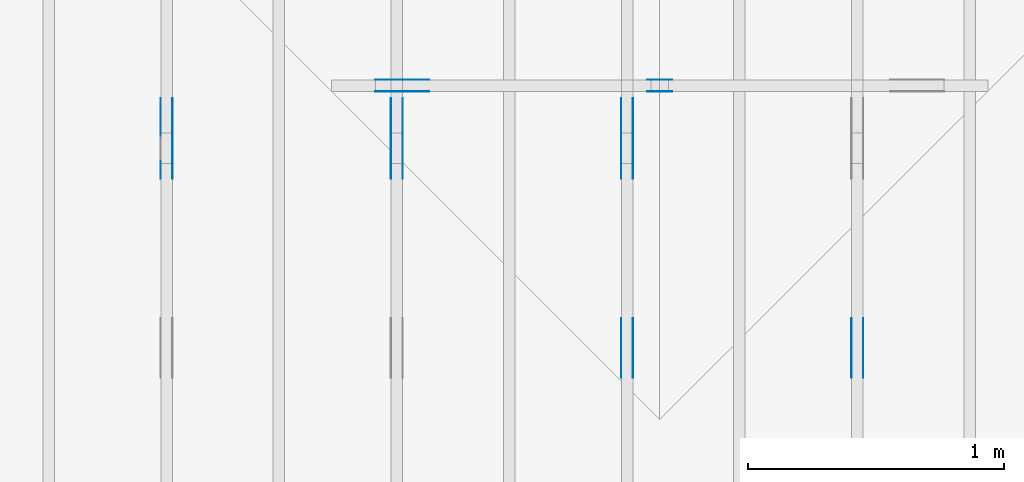
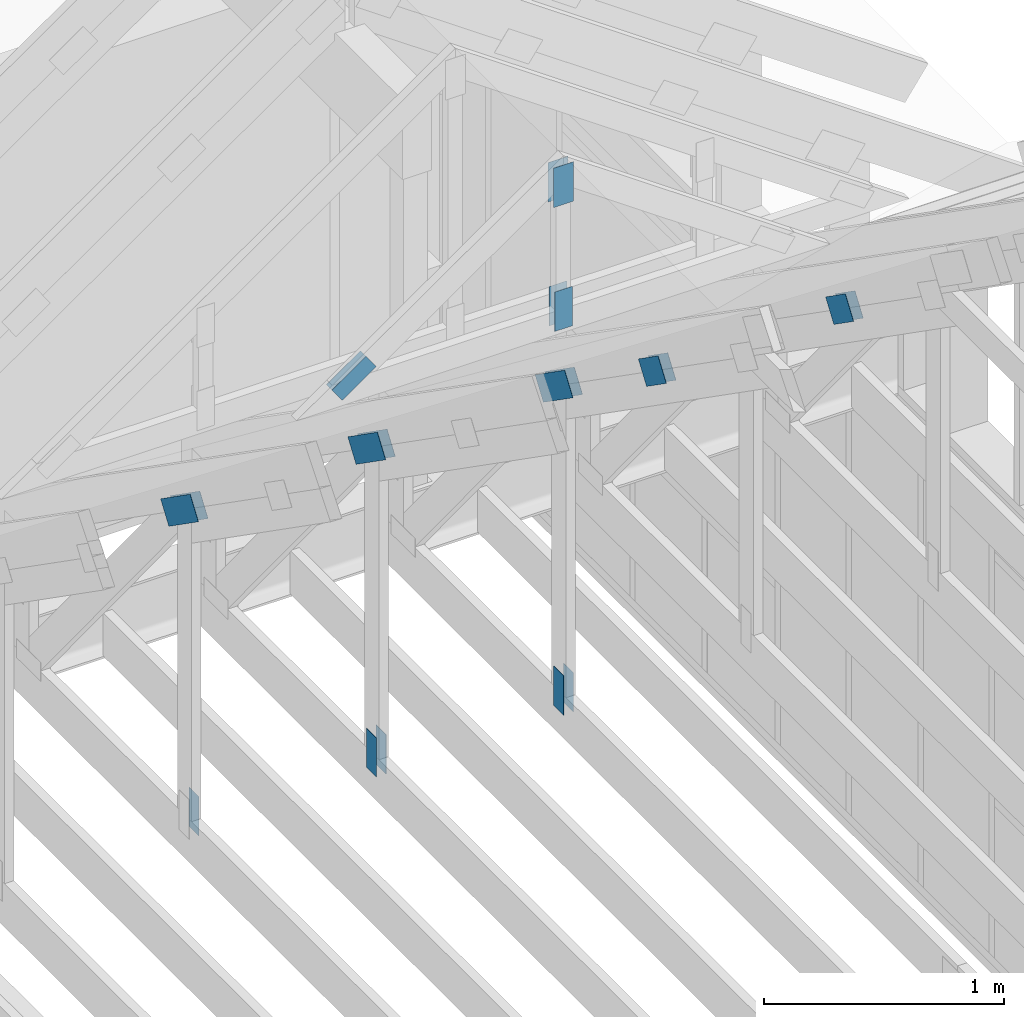
# One storey, part 57 of 70: 21 plates, 5 elements without a shape of their own.
"""IFC2X3 building model written with IfcOpenShell, lengths in millimetres."""

from ifc_helpers import new_model, si_unit, frame, origin, origin_with_axes, origin_2d, place, context, project, spatial, faceted_brep, element, aggregate, save


model = new_model("IFC2X3")

# Units and contexts
model_context = context("Model", 3, precision=1e-05, world=origin())
plan_context = context("Plan", 2, precision=1e-05, world=origin_2d())
ifc_project = project(units=[si_unit("LENGTHUNIT", "METRE", prefix="MILLI"), si_unit("AREAUNIT", "SQUARE_METRE"), si_unit("VOLUMEUNIT", "CUBIC_METRE"), si_unit("SOLIDANGLEUNIT", "STERADIAN"), si_unit("PLANEANGLEUNIT", "RADIAN"), si_unit("MASSUNIT", "GRAM"), si_unit("TIMEUNIT", "SECOND"), si_unit("THERMODYNAMICTEMPERATUREUNIT", "DEGREE_CELSIUS"), si_unit("LUMINOUSINTENSITYUNIT", "LUMEN")], contexts=[model_context, plan_context])

# Site, building, storey
site_placement = place(None, origin_with_axes())
site = spatial("IfcSite", under=ifc_project, at=site_placement, CompositionType="ELEMENT")
building_placement = place(site_placement, origin_with_axes())
building = spatial("IfcBuilding", under=site, at=building_placement, Name="Layout 1", CompositionType="ELEMENT")
storey_placement = place(building_placement, origin_with_axes())
storey = spatial("IfcBuildingStorey", under=building, at=storey_placement, Name="Storey 1", CompositionType="ELEMENT", Elevation=0.0)

# Assembly, plates
assembly_1_placement = place(storey_placement, frame((10250.0, 8000.0, -9.081170196248781e-13), z_axis=(-1.0, 1.836909530733566e-16, 6.123031769111886e-17), x_axis=(-1.836909530733566e-16, -1.0, 0.0)))
assembly_1 = element("IfcElementAssembly", 1, at=assembly_1_placement, inside=storey, Name="T3", AssemblyPlace="FACTORY", PredefinedType="TRUSS")
plate_1_placement = place(assembly_1_placement, frame((2172.1001375452647, 2209.623369923266, 0.0), z_axis=(0.0, 0.0, 1.0), x_axis=(0.8191520442889915, 0.5735764363510465, 0.0)))
plate_1 = element("IfcPlate", 2, at=plate_1_placement, context=model_context, shape_type="Brep", body=[
    faceted_brep([(200.00000000000045, 120.0, 1.3), (0.0, 120.0, 1.3), (0.0, 0.0, 1.3), (200.00000000000045, 0.0, 1.3), (0.0, 120.0, 0.0), (200.00000000000045, 120.0, 2.4492127076447602e-14), (200.00000000000045, 2.2737367544323206e-13, 2.4492127076447602e-14), (0.0, 2.2737367544323206e-13, 0.0), (200.00000000000045, 1.4089749332535406e-13, 5.2949641037927226e-30), (200.00000000000045, 1.4097709273835252e-13, 1.3), (-5.607678880825911e-32, 7.959941299845453e-17, 1.3), (0.0, 0.0, 0.0), (200.00000000000045, 120.00000000000023, 0.0), (200.00000000000045, 120.00000000000023, 1.3), (200.00000000000045, 2.2737367544323206e-13, 1.3), (200.00000000000045, 2.2737367544323206e-13, 0.0), (0.0, 120.0, 0.0), (0.0, 120.0, 1.3), (200.00000000000043, 120.00000000000021, 1.3), (200.00000000000043, 120.00000000000021, -1.5777218104420236e-30), (0.0, 0.0, 0.0), (7.959941299845453e-17, -9.747794691843893e-33, 1.3), (1.477487565886698e-14, 120.0, 1.3), (1.4695276245868527e-14, 120.0, -8.997964330932825e-31)], [[[0, 1, 2, 3]], [[4, 5, 6, 7]], [[8, 9, 10, 11]], [[12, 13, 14, 15]], [[16, 17, 18, 19]], [[20, 21, 22, 23]]]),
])
plate_2_placement = place(assembly_1_placement, frame((2172.1001375452647, 2209.623369923266, -46.29999999999999), z_axis=(0.0, 0.0, 1.0), x_axis=(0.8191520442889915, 0.5735764363510465, 0.0)))
plate_2 = element("IfcPlate", 3, at=plate_2_placement, context=model_context, shape_type="Brep", body=[
    faceted_brep([(200.00000000000045, 120.0, 1.2999999999999972), (0.0, 120.0, 1.2999999999999972), (0.0, 0.0, 1.2999999999999972), (200.00000000000045, 0.0, 1.2999999999999972), (0.0, 120.0, 0.0), (200.00000000000045, 120.0, 2.4492127076447602e-14), (200.00000000000045, 2.2737367544323206e-13, 2.4492127076447602e-14), (0.0, 2.2737367544323206e-13, 0.0), (200.00000000000045, 1.4089749332535406e-13, 5.2949641037927226e-30), (200.00000000000045, 1.4097709273835252e-13, 1.2999999999999972), (-5.607678880825899e-32, 7.959941299845434e-17, 1.2999999999999972), (0.0, 0.0, 0.0), (200.00000000000045, 120.00000000000023, 0.0), (200.00000000000045, 120.00000000000023, 1.2999999999999972), (200.00000000000045, 2.2737367544323206e-13, 1.2999999999999972), (200.00000000000045, 2.2737367544323206e-13, 0.0), (0.0, 120.0, 0.0), (0.0, 120.0, 1.2999999999999972), (200.00000000000043, 120.00000000000021, 1.2999999999999972), (200.00000000000043, 120.00000000000021, -1.5777218104420236e-30), (0.0, 0.0, 0.0), (7.959941299845434e-17, -9.747794691843873e-33, 1.2999999999999972), (1.477487565886698e-14, 120.0, 1.2999999999999972), (1.4695276245868527e-14, 120.0, -8.997964330932825e-31)], [[[0, 1, 2, 3]], [[4, 5, 6, 7]], [[8, 9, 10, 11]], [[12, 13, 14, 15]], [[16, 17, 18, 19]], [[20, 21, 22, 23]]]),
])
aggregate(assembly_1, [plate_1, plate_2])

assembly_2_placement = place(storey_placement, frame((9350.0, 8000.0, -9.081170196248781e-13), z_axis=(-1.0, 1.836909530733566e-16, 6.123031769111886e-17), x_axis=(-1.836909530733566e-16, -1.0, 0.0)))
assembly_2 = element("IfcElementAssembly", 4, at=assembly_2_placement, inside=storey, Name="T3", AssemblyPlace="FACTORY", PredefinedType="TRUSS")
plate_3_placement = place(assembly_2_placement, frame((2172.1001375452647, 2209.623369923266, 0.0), z_axis=(0.0, 0.0, 1.0), x_axis=(0.8191520442889915, 0.5735764363510465, 0.0)))
plate_3 = element("IfcPlate", 5, at=plate_3_placement, context=model_context, shape_type="Brep", body=[
    faceted_brep([(200.00000000000045, 120.0, 1.3), (0.0, 120.0, 1.3), (0.0, 0.0, 1.3), (200.00000000000045, 0.0, 1.3), (0.0, 120.0, 0.0), (200.00000000000045, 120.0, 2.4492127076447602e-14), (200.00000000000045, 2.2737367544323206e-13, 2.4492127076447602e-14), (0.0, 2.2737367544323206e-13, 0.0), (200.00000000000045, 1.4089749332535406e-13, 5.2949641037927226e-30), (200.00000000000045, 1.4097709273835252e-13, 1.3), (-5.607678880825911e-32, 7.959941299845453e-17, 1.3), (0.0, 0.0, 0.0), (200.00000000000045, 120.00000000000023, 0.0), (200.00000000000045, 120.00000000000023, 1.3), (200.00000000000045, 2.2737367544323206e-13, 1.3), (200.00000000000045, 2.2737367544323206e-13, 0.0), (0.0, 120.0, 0.0), (0.0, 120.0, 1.3), (200.00000000000043, 120.00000000000021, 1.3), (200.00000000000043, 120.00000000000021, -1.5777218104420236e-30), (0.0, 0.0, 0.0), (7.959941299845453e-17, -9.747794691843893e-33, 1.3), (1.477487565886698e-14, 120.0, 1.3), (1.4695276245868527e-14, 120.0, -8.997964330932825e-31)], [[[0, 1, 2, 3]], [[4, 5, 6, 7]], [[8, 9, 10, 11]], [[12, 13, 14, 15]], [[16, 17, 18, 19]], [[20, 21, 22, 23]]]),
])
plate_4_placement = place(assembly_2_placement, frame((2172.1001375452647, 2209.623369923266, -46.29999999999999), z_axis=(0.0, 0.0, 1.0), x_axis=(0.8191520442889915, 0.5735764363510465, 0.0)))
plate_4 = element("IfcPlate", 6, at=plate_4_placement, context=model_context, shape_type="Brep", body=[
    faceted_brep([(200.00000000000045, 120.0, 1.2999999999999972), (0.0, 120.0, 1.2999999999999972), (0.0, 0.0, 1.2999999999999972), (200.00000000000045, 0.0, 1.2999999999999972), (0.0, 120.0, 0.0), (200.00000000000045, 120.0, 2.4492127076447602e-14), (200.00000000000045, 2.2737367544323206e-13, 2.4492127076447602e-14), (0.0, 2.2737367544323206e-13, 0.0), (200.00000000000045, 1.4089749332535406e-13, 5.2949641037927226e-30), (200.00000000000045, 1.4097709273835252e-13, 1.2999999999999972), (-5.607678880825899e-32, 7.959941299845434e-17, 1.2999999999999972), (0.0, 0.0, 0.0), (200.00000000000045, 120.00000000000023, 0.0), (200.00000000000045, 120.00000000000023, 1.2999999999999972), (200.00000000000045, 2.2737367544323206e-13, 1.2999999999999972), (200.00000000000045, 2.2737367544323206e-13, 0.0), (0.0, 120.0, 0.0), (0.0, 120.0, 1.2999999999999972), (200.00000000000043, 120.00000000000021, 1.2999999999999972), (200.00000000000043, 120.00000000000021, -1.5777218104420236e-30), (0.0, 0.0, 0.0), (7.959941299845434e-17, -9.747794691843873e-33, 1.2999999999999972), (1.477487565886698e-14, 120.0, 1.2999999999999972), (1.4695276245868527e-14, 120.0, -8.997964330932825e-31)], [[[0, 1, 2, 3]], [[4, 5, 6, 7]], [[8, 9, 10, 11]], [[12, 13, 14, 15]], [[16, 17, 18, 19]], [[20, 21, 22, 23]]]),
])
plate_5_placement = place(assembly_2_placement, frame((1482.0000000018263, 120.0, 0.0), z_axis=(0.0, 0.0, 1.0), x_axis=(6.123031769111886e-17, 1.0, 0.0)))
plate_5 = element("IfcPlate", 7, at=plate_5_placement, context=model_context, shape_type="Brep", body=[
    faceted_brep([(200.00000000000003, 84.0, 1.3), (0.0, 84.0, 1.3), (0.0, 0.0, 1.3), (200.00000000000003, 0.0, 1.3), (0.0, 84.0, 0.0), (200.00000000000003, 84.0, 2.4492127076447548e-14), (200.00000000000003, 0.0, 2.4492127076447548e-14), (0.0, 0.0, 0.0), (200.00000000000003, -3.6738190614671324e-14, 2.2494910827332065e-30), (200.00000000000003, -3.665859120167287e-14, 1.3), (1.4621692037765842e-32, 7.959941299845453e-17, 1.3), (0.0, 0.0, 0.0), (200.00000000000003, 84.0, 0.0), (200.00000000000003, 84.0, 1.3), (200.00000000000003, 0.0, 1.3), (200.00000000000003, 0.0, 0.0), (0.0, 84.0, 0.0), (-4.8738973459219465e-33, 84.0, 1.3), (200.00000000000003, 83.99999999999999, 1.3), (200.00000000000003, 83.99999999999999, -7.888609052210118e-31), (0.0, 0.0, 0.0), (7.959941299845453e-17, -9.747794691843893e-33, 1.3), (1.0366292785106424e-14, 84.0, 1.3), (1.0286693372107969e-14, 84.0, -6.298575031652977e-31)], [[[0, 1, 2, 3]], [[4, 5, 6, 7]], [[8, 9, 10, 11]], [[12, 13, 14, 15]], [[16, 17, 18, 19]], [[20, 21, 22, 23]]]),
])
plate_6_placement = place(assembly_2_placement, frame((1482.0000000018263, 120.0, -46.3), z_axis=(0.0, 0.0, 1.0), x_axis=(6.123031769111886e-17, 1.0, 0.0)))
plate_6 = element("IfcPlate", 8, at=plate_6_placement, context=model_context, shape_type="Brep", body=[
    faceted_brep([(200.00000000000003, 84.0, 1.2999999999999972), (0.0, 84.0, 1.2999999999999972), (0.0, 0.0, 1.2999999999999972), (200.00000000000003, 0.0, 1.2999999999999972), (0.0, 84.0, 0.0), (200.00000000000003, 84.0, 2.4492127076447548e-14), (200.00000000000003, 0.0, 2.4492127076447548e-14), (0.0, 0.0, 0.0), (200.00000000000003, -3.6738190614671324e-14, 2.2494910827332065e-30), (200.00000000000003, -3.665859120167287e-14, 1.2999999999999972), (1.462169203776581e-32, 7.959941299845434e-17, 1.2999999999999972), (0.0, 0.0, 0.0), (200.00000000000003, 84.0, 0.0), (200.00000000000003, 84.0, 1.2999999999999972), (200.00000000000003, 0.0, 1.2999999999999972), (200.00000000000003, 0.0, 0.0), (0.0, 84.0, 0.0), (-4.873897345921936e-33, 84.0, 1.2999999999999972), (200.00000000000003, 83.99999999999999, 1.2999999999999972), (200.00000000000003, 83.99999999999999, -7.888609052210118e-31), (0.0, 0.0, 0.0), (7.959941299845434e-17, -9.747794691843873e-33, 1.2999999999999972), (1.0366292785106424e-14, 84.0, 1.2999999999999972), (1.0286693372107969e-14, 84.0, -6.298575031652977e-31)], [[[0, 1, 2, 3]], [[4, 5, 6, 7]], [[8, 9, 10, 11]], [[12, 13, 14, 15]], [[16, 17, 18, 19]], [[20, 21, 22, 23]]]),
])
plate_7_placement = place(assembly_2_placement, frame((1312.2224814137073, 1607.5305531611004, 0.0), z_axis=(0.0, 0.0, 1.0), x_axis=(0.8191520442886487, 0.5735764363515361, 0.0)))
plate_7 = element("IfcPlate", 9, at=plate_7_placement, context=model_context, shape_type="Brep", body=[
    faceted_brep([(300.00000000000045, 120.0, 1.3), (0.0, 120.0, 1.3), (4.547473508864641e-13, 0.0, 1.3), (300.00000000000045, 0.0, 1.3), (0.0, 120.0, 0.0), (300.00000000000045, 120.0, 3.6738190614671375e-14), (300.00000000000045, 1.1368683772161603e-13, 3.6738190614671375e-14), (4.547473508864641e-13, 1.1368683772161603e-13, 5.56886495279458e-29), (300.00000000000045, -5.510728592200723e-14, 1.0335317815093051e-29), (300.00000000000045, -5.5027686509008776e-14, 1.3), (4.547473508864641e-13, 7.959941299819867e-17, 1.3), (4.547473508864641e-13, -2.558622685737995e-28, 1.566652798994412e-44), (300.00000000000045, 120.00000000000011, 0.0), (300.00000000000045, 120.00000000000011, 1.3), (300.00000000000045, 1.1368683772161603e-13, 1.3), (300.00000000000045, 1.1368683772161603e-13, 0.0), (0.0, 120.0, 0.0), (0.0, 120.0, 1.3), (300.00000000000045, 120.00000000000011, 1.3), (300.00000000000045, 120.00000000000011, 0.0), (4.547473508864641e-13, 0.0, 0.0), (4.548269502994626e-13, 2.730461286921124e-31, 1.3), (4.319658508927097e-14, 120.0, 1.3), (4.3116985676272535e-14, 120.0, -2.6400667308415888e-30)], [[[0, 1, 2, 3]], [[4, 5, 6, 7]], [[8, 9, 10, 11]], [[12, 13, 14, 15]], [[16, 17, 18, 19]], [[20, 21, 22, 23]]]),
])
plate_8_placement = place(assembly_2_placement, frame((1312.2224814137073, 1607.5305531611004, -46.300000000000004), z_axis=(0.0, 0.0, 1.0), x_axis=(0.8191520442886487, 0.5735764363515361, 0.0)))
plate_8 = element("IfcPlate", 10, at=plate_8_placement, context=model_context, shape_type="Brep", body=[
    faceted_brep([(300.00000000000045, 120.0, 1.2999999999999972), (0.0, 120.0, 1.2999999999999972), (4.547473508864641e-13, 0.0, 1.2999999999999972), (300.00000000000045, 0.0, 1.2999999999999972), (0.0, 120.0, 0.0), (300.00000000000045, 120.0, 3.6738190614671375e-14), (300.00000000000045, 1.1368683772161603e-13, 3.6738190614671375e-14), (4.547473508864641e-13, 1.1368683772161603e-13, 5.56886495279458e-29), (300.00000000000045, -5.510728592200723e-14, 1.0335317815093051e-29), (300.00000000000045, -5.5027686509008776e-14, 1.2999999999999972), (4.547473508864641e-13, 7.959941299819848e-17, 1.2999999999999972), (4.547473508864641e-13, -2.558622685737995e-28, 1.566652798994412e-44), (300.00000000000045, 120.00000000000011, 0.0), (300.00000000000045, 120.00000000000011, 1.2999999999999972), (300.00000000000045, 1.1368683772161603e-13, 1.2999999999999972), (300.00000000000045, 1.1368683772161603e-13, 0.0), (0.0, 120.0, 0.0), (0.0, 120.0, 1.2999999999999972), (300.00000000000045, 120.00000000000011, 1.2999999999999972), (300.00000000000045, 120.00000000000011, 0.0), (4.547473508864641e-13, 0.0, 0.0), (4.548269502994626e-13, 2.730461286921124e-31, 1.2999999999999972), (4.319658508927097e-14, 120.0, 1.2999999999999972), (4.3116985676272535e-14, 120.0, -2.6400667308415888e-30)], [[[0, 1, 2, 3]], [[4, 5, 6, 7]], [[8, 9, 10, 11]], [[12, 13, 14, 15]], [[16, 17, 18, 19]], [[20, 21, 22, 23]]]),
])
aggregate(assembly_2, [plate_3, plate_4, plate_5, plate_6, plate_7, plate_8])

assembly_3_placement = place(storey_placement, frame((8450.0, 8000.0, -9.081170196248781e-13), z_axis=(-1.0, 1.836909530733566e-16, 6.123031769111886e-17), x_axis=(-1.836909530733566e-16, -1.0, 0.0)))
assembly_3 = element("IfcElementAssembly", 11, at=assembly_3_placement, inside=storey, Name="T3", AssemblyPlace="FACTORY", PredefinedType="TRUSS")
plate_9_placement = place(assembly_3_placement, frame((1482.0000000018263, 120.0, 0.0), z_axis=(0.0, 0.0, 1.0), x_axis=(6.123031769111886e-17, 1.0, 0.0)))
plate_9 = element("IfcPlate", 12, at=plate_9_placement, context=model_context, shape_type="Brep", body=[
    faceted_brep([(200.00000000000003, 84.0, 1.3), (0.0, 84.0, 1.3), (0.0, 0.0, 1.3), (200.00000000000003, 0.0, 1.3), (0.0, 84.0, 0.0), (200.00000000000003, 84.0, 2.4492127076447548e-14), (200.00000000000003, 0.0, 2.4492127076447548e-14), (0.0, 0.0, 0.0), (200.00000000000003, -3.6738190614671324e-14, 2.2494910827332065e-30), (200.00000000000003, -3.665859120167287e-14, 1.3), (1.4621692037765842e-32, 7.959941299845453e-17, 1.3), (0.0, 0.0, 0.0), (200.00000000000003, 84.0, 0.0), (200.00000000000003, 84.0, 1.3), (200.00000000000003, 0.0, 1.3), (200.00000000000003, 0.0, 0.0), (0.0, 84.0, 0.0), (-4.8738973459219465e-33, 84.0, 1.3), (200.00000000000003, 83.99999999999999, 1.3), (200.00000000000003, 83.99999999999999, -7.888609052210118e-31), (0.0, 0.0, 0.0), (7.959941299845453e-17, -9.747794691843893e-33, 1.3), (1.0366292785106424e-14, 84.0, 1.3), (1.0286693372107969e-14, 84.0, -6.298575031652977e-31)], [[[0, 1, 2, 3]], [[4, 5, 6, 7]], [[8, 9, 10, 11]], [[12, 13, 14, 15]], [[16, 17, 18, 19]], [[20, 21, 22, 23]]]),
])
plate_10_placement = place(assembly_3_placement, frame((1482.0000000018263, 120.0, -46.3), z_axis=(0.0, 0.0, 1.0), x_axis=(6.123031769111886e-17, 1.0, 0.0)))
plate_10 = element("IfcPlate", 13, at=plate_10_placement, context=model_context, shape_type="Brep", body=[
    faceted_brep([(200.00000000000003, 84.0, 1.2999999999999972), (0.0, 84.0, 1.2999999999999972), (0.0, 0.0, 1.2999999999999972), (200.00000000000003, 0.0, 1.2999999999999972), (0.0, 84.0, 0.0), (200.00000000000003, 84.0, 2.4492127076447548e-14), (200.00000000000003, 0.0, 2.4492127076447548e-14), (0.0, 0.0, 0.0), (200.00000000000003, -3.6738190614671324e-14, 2.2494910827332065e-30), (200.00000000000003, -3.665859120167287e-14, 1.2999999999999972), (1.462169203776581e-32, 7.959941299845434e-17, 1.2999999999999972), (0.0, 0.0, 0.0), (200.00000000000003, 84.0, 0.0), (200.00000000000003, 84.0, 1.2999999999999972), (200.00000000000003, 0.0, 1.2999999999999972), (200.00000000000003, 0.0, 0.0), (0.0, 84.0, 0.0), (-4.873897345921936e-33, 84.0, 1.2999999999999972), (200.00000000000003, 83.99999999999999, 1.2999999999999972), (200.00000000000003, 83.99999999999999, -7.888609052210118e-31), (0.0, 0.0, 0.0), (7.959941299845434e-17, -9.747794691843873e-33, 1.2999999999999972), (1.0366292785106424e-14, 84.0, 1.2999999999999972), (1.0286693372107969e-14, 84.0, -6.298575031652977e-31)], [[[0, 1, 2, 3]], [[4, 5, 6, 7]], [[8, 9, 10, 11]], [[12, 13, 14, 15]], [[16, 17, 18, 19]], [[20, 21, 22, 23]]]),
])
plate_11_placement = place(assembly_3_placement, frame((1312.2224814137073, 1607.5305531611004, 0.0), z_axis=(0.0, 0.0, 1.0), x_axis=(0.8191520442886487, 0.5735764363515361, 0.0)))
plate_11 = element("IfcPlate", 14, at=plate_11_placement, context=model_context, shape_type="Brep", body=[
    faceted_brep([(300.00000000000045, 120.0, 1.3), (0.0, 120.0, 1.3), (4.547473508864641e-13, 0.0, 1.3), (300.00000000000045, 0.0, 1.3), (0.0, 120.0, 0.0), (300.00000000000045, 120.0, 3.6738190614671375e-14), (300.00000000000045, 1.1368683772161603e-13, 3.6738190614671375e-14), (4.547473508864641e-13, 1.1368683772161603e-13, 5.56886495279458e-29), (300.00000000000045, -5.510728592200723e-14, 1.0335317815093051e-29), (300.00000000000045, -5.5027686509008776e-14, 1.3), (4.547473508864641e-13, 7.959941299819867e-17, 1.3), (4.547473508864641e-13, -2.558622685737995e-28, 1.566652798994412e-44), (300.00000000000045, 120.00000000000011, 0.0), (300.00000000000045, 120.00000000000011, 1.3), (300.00000000000045, 1.1368683772161603e-13, 1.3), (300.00000000000045, 1.1368683772161603e-13, 0.0), (0.0, 120.0, 0.0), (0.0, 120.0, 1.3), (300.00000000000045, 120.00000000000011, 1.3), (300.00000000000045, 120.00000000000011, 0.0), (4.547473508864641e-13, 0.0, 0.0), (4.548269502994626e-13, 2.730461286921124e-31, 1.3), (4.319658508927097e-14, 120.0, 1.3), (4.3116985676272535e-14, 120.0, -2.6400667308415888e-30)], [[[0, 1, 2, 3]], [[4, 5, 6, 7]], [[8, 9, 10, 11]], [[12, 13, 14, 15]], [[16, 17, 18, 19]], [[20, 21, 22, 23]]]),
])
plate_12_placement = place(assembly_3_placement, frame((1312.2224814137073, 1607.5305531611004, -46.300000000000004), z_axis=(0.0, 0.0, 1.0), x_axis=(0.8191520442886487, 0.5735764363515361, 0.0)))
plate_12 = element("IfcPlate", 15, at=plate_12_placement, context=model_context, shape_type="Brep", body=[
    faceted_brep([(300.00000000000045, 120.0, 1.2999999999999972), (0.0, 120.0, 1.2999999999999972), (4.547473508864641e-13, 0.0, 1.2999999999999972), (300.00000000000045, 0.0, 1.2999999999999972), (0.0, 120.0, 0.0), (300.00000000000045, 120.0, 3.6738190614671375e-14), (300.00000000000045, 1.1368683772161603e-13, 3.6738190614671375e-14), (4.547473508864641e-13, 1.1368683772161603e-13, 5.56886495279458e-29), (300.00000000000045, -5.510728592200723e-14, 1.0335317815093051e-29), (300.00000000000045, -5.5027686509008776e-14, 1.2999999999999972), (4.547473508864641e-13, 7.959941299819848e-17, 1.2999999999999972), (4.547473508864641e-13, -2.558622685737995e-28, 1.566652798994412e-44), (300.00000000000045, 120.00000000000011, 0.0), (300.00000000000045, 120.00000000000011, 1.2999999999999972), (300.00000000000045, 1.1368683772161603e-13, 1.2999999999999972), (300.00000000000045, 1.1368683772161603e-13, 0.0), (0.0, 120.0, 0.0), (0.0, 120.0, 1.2999999999999972), (300.00000000000045, 120.00000000000011, 1.2999999999999972), (300.00000000000045, 120.00000000000011, 0.0), (4.547473508864641e-13, 0.0, 0.0), (4.548269502994626e-13, 2.730461286921124e-31, 1.2999999999999972), (4.319658508927097e-14, 120.0, 1.2999999999999972), (4.3116985676272535e-14, 120.0, -2.6400667308415888e-30)], [[[0, 1, 2, 3]], [[4, 5, 6, 7]], [[8, 9, 10, 11]], [[12, 13, 14, 15]], [[16, 17, 18, 19]], [[20, 21, 22, 23]]]),
])
aggregate(assembly_3, [plate_9, plate_10, plate_11, plate_12])

assembly_4_placement = place(storey_placement, frame((7550.000000000001, 8000.0, -9.081170196248781e-13), z_axis=(-1.0, 1.836909530733566e-16, 6.123031769111886e-17), x_axis=(-1.836909530733566e-16, -1.0, 0.0)))
assembly_4 = element("IfcElementAssembly", 16, at=assembly_4_placement, inside=storey, Name="T3", AssemblyPlace="FACTORY", PredefinedType="TRUSS")
plate_13_placement = place(assembly_4_placement, frame((1482.0000000018263, 120.0, -46.3), z_axis=(0.0, 0.0, 1.0), x_axis=(6.123031769111886e-17, 1.0, 0.0)))
plate_13 = element("IfcPlate", 17, at=plate_13_placement, context=model_context, shape_type="Brep", body=[
    faceted_brep([(200.00000000000003, 84.0, 1.2999999999999972), (0.0, 84.0, 1.2999999999999972), (0.0, 0.0, 1.2999999999999972), (200.00000000000003, 0.0, 1.2999999999999972), (0.0, 84.0, 0.0), (200.00000000000003, 84.0, 2.4492127076447548e-14), (200.00000000000003, 0.0, 2.4492127076447548e-14), (0.0, 0.0, 0.0), (200.00000000000003, -3.6738190614671324e-14, 2.2494910827332065e-30), (200.00000000000003, -3.665859120167287e-14, 1.2999999999999972), (1.462169203776581e-32, 7.959941299845434e-17, 1.2999999999999972), (0.0, 0.0, 0.0), (200.00000000000003, 84.0, 0.0), (200.00000000000003, 84.0, 1.2999999999999972), (200.00000000000003, 0.0, 1.2999999999999972), (200.00000000000003, 0.0, 0.0), (0.0, 84.0, 0.0), (-4.873897345921936e-33, 84.0, 1.2999999999999972), (200.00000000000003, 83.99999999999999, 1.2999999999999972), (200.00000000000003, 83.99999999999999, -7.888609052210118e-31), (0.0, 0.0, 0.0), (7.959941299845434e-17, -9.747794691843873e-33, 1.2999999999999972), (1.0366292785106424e-14, 84.0, 1.2999999999999972), (1.0286693372107969e-14, 84.0, -6.298575031652977e-31)], [[[0, 1, 2, 3]], [[4, 5, 6, 7]], [[8, 9, 10, 11]], [[12, 13, 14, 15]], [[16, 17, 18, 19]], [[20, 21, 22, 23]]]),
])
plate_14_placement = place(assembly_4_placement, frame((1312.2224814137073, 1607.5305531611004, 0.0), z_axis=(0.0, 0.0, 1.0), x_axis=(0.8191520442886487, 0.5735764363515361, 0.0)))
plate_14 = element("IfcPlate", 18, at=plate_14_placement, context=model_context, shape_type="Brep", body=[
    faceted_brep([(300.00000000000045, 120.0, 1.3), (0.0, 120.0, 1.3), (4.547473508864641e-13, 0.0, 1.3), (300.00000000000045, 0.0, 1.3), (0.0, 120.0, 0.0), (300.00000000000045, 120.0, 3.6738190614671375e-14), (300.00000000000045, 1.1368683772161603e-13, 3.6738190614671375e-14), (4.547473508864641e-13, 1.1368683772161603e-13, 5.56886495279458e-29), (300.00000000000045, -5.510728592200723e-14, 1.0335317815093051e-29), (300.00000000000045, -5.5027686509008776e-14, 1.3), (4.547473508864641e-13, 7.959941299819867e-17, 1.3), (4.547473508864641e-13, -2.558622685737995e-28, 1.566652798994412e-44), (300.00000000000045, 120.00000000000011, 0.0), (300.00000000000045, 120.00000000000011, 1.3), (300.00000000000045, 1.1368683772161603e-13, 1.3), (300.00000000000045, 1.1368683772161603e-13, 0.0), (0.0, 120.0, 0.0), (0.0, 120.0, 1.3), (300.00000000000045, 120.00000000000011, 1.3), (300.00000000000045, 120.00000000000011, 0.0), (4.547473508864641e-13, 0.0, 0.0), (4.548269502994626e-13, 2.730461286921124e-31, 1.3), (4.319658508927097e-14, 120.0, 1.3), (4.3116985676272535e-14, 120.0, -2.6400667308415888e-30)], [[[0, 1, 2, 3]], [[4, 5, 6, 7]], [[8, 9, 10, 11]], [[12, 13, 14, 15]], [[16, 17, 18, 19]], [[20, 21, 22, 23]]]),
])
plate_15_placement = place(assembly_4_placement, frame((1312.2224814137073, 1607.5305531611004, -46.300000000000004), z_axis=(0.0, 0.0, 1.0), x_axis=(0.8191520442886487, 0.5735764363515361, 0.0)))
plate_15 = element("IfcPlate", 19, at=plate_15_placement, context=model_context, shape_type="Brep", body=[
    faceted_brep([(300.00000000000045, 120.0, 1.2999999999999972), (0.0, 120.0, 1.2999999999999972), (4.547473508864641e-13, 0.0, 1.2999999999999972), (300.00000000000045, 0.0, 1.2999999999999972), (0.0, 120.0, 0.0), (300.00000000000045, 120.0, 3.6738190614671375e-14), (300.00000000000045, 1.1368683772161603e-13, 3.6738190614671375e-14), (4.547473508864641e-13, 1.1368683772161603e-13, 5.56886495279458e-29), (300.00000000000045, -5.510728592200723e-14, 1.0335317815093051e-29), (300.00000000000045, -5.5027686509008776e-14, 1.2999999999999972), (4.547473508864641e-13, 7.959941299819848e-17, 1.2999999999999972), (4.547473508864641e-13, -2.558622685737995e-28, 1.566652798994412e-44), (300.00000000000045, 120.00000000000011, 0.0), (300.00000000000045, 120.00000000000011, 1.2999999999999972), (300.00000000000045, 1.1368683772161603e-13, 1.2999999999999972), (300.00000000000045, 1.1368683772161603e-13, 0.0), (0.0, 120.0, 0.0), (0.0, 120.0, 1.2999999999999972), (300.00000000000045, 120.00000000000011, 1.2999999999999972), (300.00000000000045, 120.00000000000011, 0.0), (4.547473508864641e-13, 0.0, 0.0), (4.548269502994626e-13, 2.730461286921124e-31, 1.2999999999999972), (4.319658508927097e-14, 120.0, 1.2999999999999972), (4.3116985676272535e-14, 120.0, -2.6400667308415888e-30)], [[[0, 1, 2, 3]], [[4, 5, 6, 7]], [[8, 9, 10, 11]], [[12, 13, 14, 15]], [[16, 17, 18, 19]], [[20, 21, 22, 23]]]),
])
aggregate(assembly_4, [plate_13, plate_14, plate_15])

assembly_5_placement = place(storey_placement, frame((8194.999999999996, 6782.5, 1836.748008160603), z_axis=(0.0, -1.0, 6.123031769111886e-17), x_axis=(1.0, 0.0, 0.0)))
assembly_5 = element("IfcElementAssembly", 20, at=assembly_5_placement, inside=storey, Name="SB2", AssemblyPlace="FACTORY", PredefinedType="TRUSS")
plate_16_placement = place(assembly_5_placement, frame((240.6595744443709, 43.99264011447549, 0.0), z_axis=(0.0, 0.0, 1.0), x_axis=(0.8191520442889915, 0.5735764363510465, 0.0)))
plate_16 = element("IfcPlate", 21, at=plate_16_placement, context=model_context, shape_type="Brep", body=[
    faceted_brep([(200.00000000000006, 84.00000000000003, 1.3), (0.0, 84.00000000000003, 1.3), (0.0, 2.842170943040401e-14, 1.3), (200.0, 2.842170943040401e-14, 1.3), (0.0, 84.00000000000003, 0.0), (200.00000000000006, 84.00000000000003, 2.449212707644755e-14), (200.0, 0.0, 2.4492127076447545e-14), (0.0, 0.0, 0.0), (200.0, -8.31648118426731e-15, 5.092207849848998e-31), (200.0, -8.236881771268857e-15, 1.3), (1.462169203776556e-32, 2.850130884340246e-14, 1.3), (0.0, 2.842170943040401e-14, 0.0), (200.0, 83.99999999999997, -3.1554436208840472e-30), (200.0, 83.99999999999997, 1.3), (200.0, 0.0, 1.3), (200.0, 0.0, 0.0), (0.0, 84.00000000000003, 0.0), (0.0, 84.00000000000003, 1.3), (200.00000000000006, 83.99999999999997, 1.3), (200.00000000000006, 83.99999999999997, 0.0), (3.4805405954966126e-30, 2.842170943040401e-14, -2.1311460639909362e-46), (7.9599412998458e-17, 2.842170943040401e-14, 1.3), (1.0366292785106427e-14, 84.00000000000003, 1.3), (1.0286693372107972e-14, 84.00000000000003, -6.298575031652979e-31)], [[[0, 1, 2, 3]], [[4, 5, 6, 7]], [[8, 9, 10, 11]], [[12, 13, 14, 15]], [[16, 17, 18, 19]], [[20, 21, 22, 23]]]),
])
plate_17_placement = place(assembly_5_placement, frame((240.6595744443709, 43.99264011447549, -46.29999999999999), z_axis=(0.0, 0.0, 1.0), x_axis=(0.8191520442889915, 0.5735764363510465, 0.0)))
plate_17 = element("IfcPlate", 22, at=plate_17_placement, context=model_context, shape_type="Brep", body=[
    faceted_brep([(200.00000000000006, 84.00000000000003, 1.2999999999999972), (0.0, 84.00000000000003, 1.2999999999999972), (0.0, 2.842170943040401e-14, 1.2999999999999972), (200.0, 2.842170943040401e-14, 1.2999999999999972), (0.0, 84.00000000000003, 0.0), (200.00000000000006, 84.00000000000003, 2.449212707644755e-14), (200.0, 0.0, 2.4492127076447545e-14), (0.0, 0.0, 0.0), (200.0, -8.31648118426731e-15, 5.092207849848998e-31), (200.0, -8.236881771268857e-15, 1.2999999999999972), (1.462169203776556e-32, 2.850130884340246e-14, 1.2999999999999972), (0.0, 2.842170943040401e-14, 0.0), (200.0, 83.99999999999997, -3.1554436208840472e-30), (200.0, 83.99999999999997, 1.2999999999999972), (200.0, 0.0, 1.2999999999999972), (200.0, 0.0, 0.0), (0.0, 84.00000000000003, 0.0), (0.0, 84.00000000000003, 1.2999999999999972), (200.00000000000006, 83.99999999999997, 1.2999999999999972), (200.00000000000006, 83.99999999999997, 0.0), (3.4805405954966126e-30, 2.842170943040401e-14, -2.1311460639909362e-46), (7.959941299845782e-17, 2.842170943040401e-14, 1.2999999999999972), (1.0366292785106427e-14, 84.00000000000003, 1.2999999999999972), (1.0286693372107972e-14, 84.00000000000003, -6.298575031652979e-31)], [[[0, 1, 2, 3]], [[4, 5, 6, 7]], [[8, 9, 10, 11]], [[12, 13, 14, 15]], [[16, 17, 18, 19]], [[20, 21, 22, 23]]]),
])
plate_18_placement = place(assembly_5_placement, frame((1257.0000000000016, 867.2778867129236, 0.0), z_axis=(0.0, 0.0, 1.0), x_axis=(9.49408737391244e-16, -1.0, 0.0)))
plate_18 = element("IfcPlate", 23, at=plate_18_placement, context=model_context, shape_type="Brep", body=[
    faceted_brep([(200.0, 96.0, 1.3), (0.0, 96.0, 1.3), (0.0, 0.0, 1.3), (200.0, 0.0, 1.3), (0.0, 96.0, 0.0), (200.0, 96.0, 2.4492127076447545e-14), (200.0, 0.0, 2.4492127076447545e-14), (0.0, 0.0, 0.0), (200.0, -3.673819061467132e-14, 2.249491082733206e-30), (200.0, -3.6658591201672864e-14, 1.3), (1.4621692037765842e-32, 7.959941299845453e-17, 1.3), (0.0, 0.0, 0.0), (200.0, 96.0, 0.0), (200.0, 96.0, 1.3), (200.0, 0.0, 1.3), (200.0, 0.0, 0.0), (0.0, 96.0, 0.0), (-4.8738973459219465e-33, 96.0, 1.3), (200.0, 95.99999999999999, 1.3), (200.0, 95.99999999999999, -7.888609052210118e-31), (0.0, 0.0, 0.0), (7.959941299845453e-17, -9.747794691843893e-33, 1.3), (1.1835820409693277e-14, 96.0, 1.3), (1.1756220996694822e-14, 96.0, -7.19837146474626e-31)], [[[0, 1, 2, 3]], [[4, 5, 6, 7]], [[8, 9, 10, 11]], [[12, 13, 14, 15]], [[16, 17, 18, 19]], [[20, 21, 22, 23]]]),
])
plate_19_placement = place(assembly_5_placement, frame((1257.0000000000016, 867.2778867129236, -46.3), z_axis=(0.0, 0.0, 1.0), x_axis=(9.49408737391244e-16, -1.0, 0.0)))
plate_19 = element("IfcPlate", 24, at=plate_19_placement, context=model_context, shape_type="Brep", body=[
    faceted_brep([(200.0, 96.0, 1.2999999999999972), (0.0, 96.0, 1.2999999999999972), (0.0, 0.0, 1.2999999999999972), (200.0, 0.0, 1.2999999999999972), (0.0, 96.0, 0.0), (200.0, 96.0, 2.4492127076447545e-14), (200.0, 0.0, 2.4492127076447545e-14), (0.0, 0.0, 0.0), (200.0, -3.673819061467132e-14, 2.249491082733206e-30), (200.0, -3.6658591201672864e-14, 1.2999999999999972), (1.462169203776581e-32, 7.959941299845434e-17, 1.2999999999999972), (0.0, 0.0, 0.0), (200.0, 96.0, 0.0), (200.0, 96.0, 1.2999999999999972), (200.0, 0.0, 1.2999999999999972), (200.0, 0.0, 0.0), (0.0, 96.0, 0.0), (-4.873897345921936e-33, 96.0, 1.2999999999999972), (200.0, 95.99999999999999, 1.2999999999999972), (200.0, 95.99999999999999, -7.888609052210118e-31), (0.0, 0.0, 0.0), (7.959941299845434e-17, -9.747794691843873e-33, 1.2999999999999972), (1.1835820409693277e-14, 96.0, 1.2999999999999972), (1.1756220996694822e-14, 96.0, -7.19837146474626e-31)], [[[0, 1, 2, 3]], [[4, 5, 6, 7]], [[8, 9, 10, 11]], [[12, 13, 14, 15]], [[16, 17, 18, 19]], [[20, 21, 22, 23]]]),
])
plate_20_placement = place(assembly_5_placement, frame((1347.0000000000016, 35.75466960947962, 0.0), z_axis=(0.0, 0.0, 1.0), x_axis=(-3.8285889215894375e-16, 1.0, 0.0)))
plate_20 = element("IfcPlate", 25, at=plate_20_placement, context=model_context, shape_type="Brep", body=[
    faceted_brep([(200.0, 84.0, 1.3), (0.0, 84.0, 1.3), (0.0, 0.0, 1.3), (200.0, 0.0, 1.3), (0.0, 84.0, 0.0), (200.0, 84.0, 2.4492127076447545e-14), (200.0, 0.0, 2.4492127076447545e-14), (0.0, 0.0, 0.0), (200.0, -3.673819061467132e-14, 2.249491082733206e-30), (200.0, -3.6658591201672864e-14, 1.3), (1.4621692037765842e-32, 7.959941299845453e-17, 1.3), (0.0, 0.0, 0.0), (200.0, 84.0, 0.0), (200.0, 84.0, 1.3), (200.0, 0.0, 1.3), (200.0, 0.0, 0.0), (0.0, 84.0, 0.0), (-4.8738973459219465e-33, 84.0, 1.3), (200.0, 83.99999999999999, 1.3), (200.0, 83.99999999999999, -7.888609052210118e-31), (0.0, 0.0, 0.0), (7.959941299845453e-17, -9.747794691843893e-33, 1.3), (1.0366292785106424e-14, 84.0, 1.3), (1.0286693372107969e-14, 84.0, -6.298575031652977e-31)], [[[0, 1, 2, 3]], [[4, 5, 6, 7]], [[8, 9, 10, 11]], [[12, 13, 14, 15]], [[16, 17, 18, 19]], [[20, 21, 22, 23]]]),
])
plate_21_placement = place(assembly_5_placement, frame((1347.0000000000016, 35.75466960947962, -46.3), z_axis=(0.0, 0.0, 1.0), x_axis=(-3.8285889215894375e-16, 1.0, 0.0)))
plate_21 = element("IfcPlate", 26, at=plate_21_placement, context=model_context, shape_type="Brep", body=[
    faceted_brep([(200.0, 84.0, 1.2999999999999972), (0.0, 84.0, 1.2999999999999972), (0.0, 0.0, 1.2999999999999972), (200.0, 0.0, 1.2999999999999972), (0.0, 84.0, 0.0), (200.0, 84.0, 2.4492127076447545e-14), (200.0, 0.0, 2.4492127076447545e-14), (0.0, 0.0, 0.0), (200.0, -3.673819061467132e-14, 2.249491082733206e-30), (200.0, -3.6658591201672864e-14, 1.2999999999999972), (1.462169203776581e-32, 7.959941299845434e-17, 1.2999999999999972), (0.0, 0.0, 0.0), (200.0, 84.0, 0.0), (200.0, 84.0, 1.2999999999999972), (200.0, 0.0, 1.2999999999999972), (200.0, 0.0, 0.0), (0.0, 84.0, 0.0), (-4.873897345921936e-33, 84.0, 1.2999999999999972), (200.0, 83.99999999999999, 1.2999999999999972), (200.0, 83.99999999999999, -7.888609052210118e-31), (0.0, 0.0, 0.0), (7.959941299845434e-17, -9.747794691843873e-33, 1.2999999999999972), (1.0366292785106424e-14, 84.0, 1.2999999999999972), (1.0286693372107969e-14, 84.0, -6.298575031652977e-31)], [[[0, 1, 2, 3]], [[4, 5, 6, 7]], [[8, 9, 10, 11]], [[12, 13, 14, 15]], [[16, 17, 18, 19]], [[20, 21, 22, 23]]]),
])
aggregate(assembly_5, [plate_16, plate_17, plate_18, plate_19, plate_20, plate_21])

save(model, "model.ifc")
